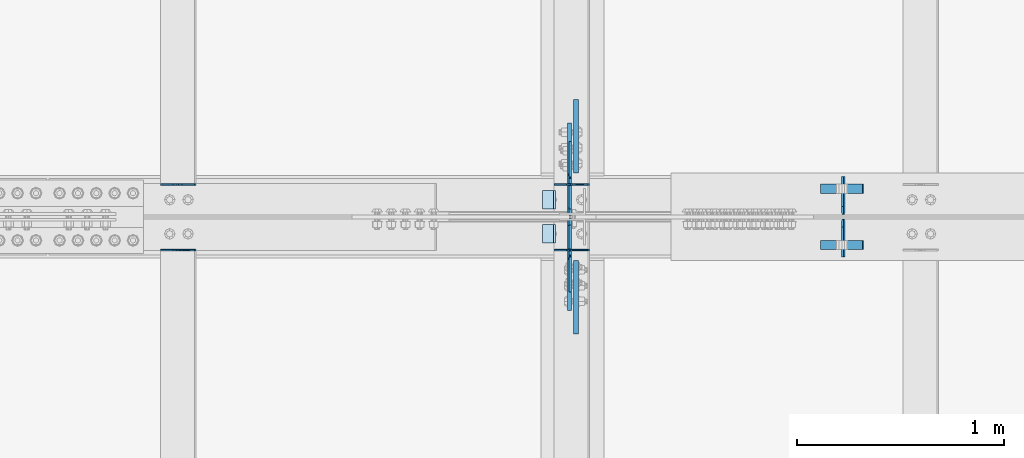
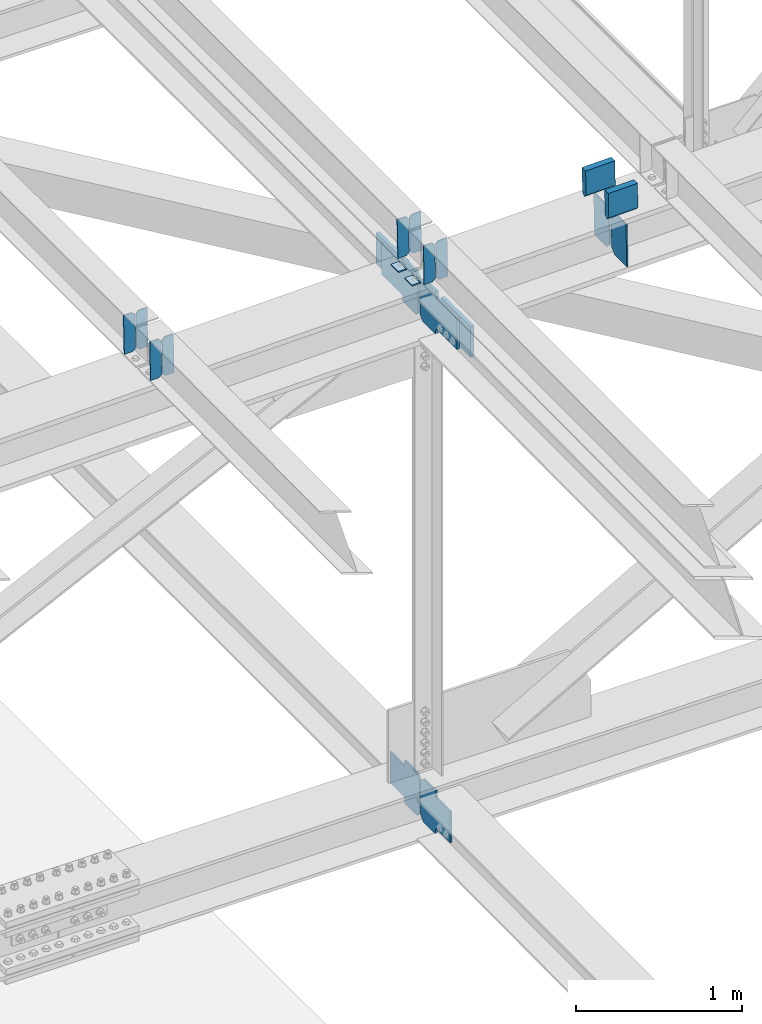
# One storey, part 3301 of 3843: 20 plates, 8 elements without a shape of their own.
"""IFC2X3 building model written with IfcOpenShell, lengths in millimetres."""

from ifc_helpers import new_model, si_unit, frame, origin_with_axes, place, context, subcontext, project, spatial, faceted_brep, material, type_object, element, aggregate, save


model = new_model("IFC2X3")

# Units and contexts
model_context = context("Model", 3, precision=1e-05, world=origin_with_axes())
body_context = subcontext(model_context, "Body", "Model", "MODEL_VIEW")
ifc_project = project(units=[si_unit("LENGTHUNIT", "METRE", prefix="MILLI"), si_unit("AREAUNIT", "SQUARE_METRE"), si_unit("VOLUMEUNIT", "CUBIC_METRE"), si_unit("MASSUNIT", "GRAM", prefix="KILO"), si_unit("TIMEUNIT", "SECOND"), si_unit("PLANEANGLEUNIT", "RADIAN"), si_unit("SOLIDANGLEUNIT", "STERADIAN"), si_unit("THERMODYNAMICTEMPERATUREUNIT", "DEGREE_CELSIUS"), si_unit("LUMINOUSINTENSITYUNIT", "LUMEN")], contexts=[model_context])

# Site, building, storey
site_placement = place(None, origin_with_axes())
site = spatial("IfcSite", under=ifc_project, at=site_placement, CompositionType="ELEMENT")
building_placement = place(site_placement, origin_with_axes())
building = spatial("IfcBuilding", under=site, at=building_placement, Name="Undefined", CompositionType="ELEMENT")
storey_placement = place(building_placement, origin_with_axes())
storey = spatial("IfcBuildingStorey", under=building, at=storey_placement, Name="Undefined", CompositionType="ELEMENT", Elevation=0.0)

# Assembly, plates
assembly_1_placement = place(storey_placement, origin_with_axes())
assembly_1 = element("IfcElementAssembly", 1, at=assembly_1_placement, inside=storey, Name="BEAM", AssemblyPlace="NOTDEFINED", PredefinedType="RIGID_FRAME")
ifc_material = material(Name="STEEL/A572-50")
plate_type_1 = type_object("IfcPlateType", PredefinedType="NOTDEFINED")
plate_1_placement = place(assembly_1_placement, frame((70338.6964783417, 42358.2999050559, 46224.2171587909), z_axis=(-0.0211520975484892, -0.00209727199913323, 0.999774069587455), x_axis=(-0.999776269356949, 4.43720000274898e-05, -0.0211520510075548)))
plate_1 = element("IfcPlate", 2, at=plate_1_placement, type_object=plate_type_1, material=ifc_material, Name="PLATE", context=body_context, shape_type="Brep", body=[
    faceted_brep([(0.0, -3.17499999999927, 0.0), (6.83940015733242e-10, -3.17499999996653, 288.924999998613), (6.54836185276508e-10, 3.17500000001746, 288.924999998591), (0.0, 3.17499999999927, 0.0), (60.3250007643655, -3.17500000017753, 288.924999998606), (60.3250007643219, 3.17499999979918, 288.924999998584), (79.3750000013097, -3.17500000025029, 269.875000761494), (79.375000001266, 3.17499999972642, 269.875000761487), (79.375000000713, -3.17500000026484, 19.0499992370605), (79.3750000006985, 3.17499999971187, 19.0499992370533), (60.325000763667, -3.17500000020664, -1.45519152283669e-11), (60.3250007636234, 3.17499999977736, -3.63797880709171e-11)], [[[0, 1, 2, 3]], [[1, 4, 5, 2]], [[4, 6, 7, 5]], [[6, 8, 9, 7]], [[8, 10, 11, 9]], [[10, 0, 3, 11]], [[5, 7, 9, 11, 3, 2]], [[10, 8, 6, 4, 1, 0]]]),
])
plate_2_placement = place(assembly_1_placement, frame((70252.9906576514, 42358.3037088136, 46222.4038991801), z_axis=(-0.0211520975484892, -0.00209727199913323, 0.999774069587455), x_axis=(-0.999776269356949, 4.43720000274898e-05, -0.0211520510075548)))
plate_2 = element("IfcPlate", 3, at=plate_2_placement, type_object=plate_type_1, material=ifc_material, Name="PLATE", context=body_context, shape_type="Brep", body=[
    faceted_brep([(4.36557456851006e-11, -3.17499999998836, 19.0499992370969), (6.11180439591408e-10, -3.17499999996653, 269.875000761516), (5.96628524363041e-10, 3.17500000001746, 269.875000761502), (1.45519152283669e-11, 3.17499999998836, 19.0499992370824), (19.0499992376572, -3.17500000003201, 288.924999998606), (19.0499992376281, 3.1749999999447, 288.924999998584), (79.3750000013242, -3.17500000025029, 288.924999998591), (79.3750000013097, 3.1749999997337, 288.92499999857), (79.3750000006548, -3.17500000026484, -2.18278728425503e-11), (79.3750000006403, 3.17499999969732, -2.91038304567337e-11), (19.0499992370023, -3.17500000005384, 0.0), (19.0499992369587, 3.17499999992287, -1.45519152283669e-11)], [[[0, 1, 2, 3]], [[1, 4, 5, 2]], [[4, 6, 7, 5]], [[6, 8, 9, 7]], [[8, 10, 11, 9]], [[10, 0, 3, 11]], [[5, 7, 9, 11, 3, 2]], [[10, 8, 6, 4, 1, 0]]]),
])

assembly_2_placement = place(storey_placement, origin_with_axes())
assembly_2 = element("IfcElementAssembly", 4, at=assembly_2_placement, inside=storey, Name="BEAM", AssemblyPlace="NOTDEFINED", PredefinedType="RIGID_FRAME")
plate_3_placement = place(assembly_2_placement, frame((70338.696478342, 42042.4624119039, 46222.6703412042), z_axis=(-0.021152098167775, -0.00763724799704507, 0.999747098613511), x_axis=(-0.999776269343847, 0.000161580000015114, -0.0211514810073172)))
plate_3 = element("IfcPlate", 5, at=plate_3_placement, type_object=plate_type_1, material=ifc_material, Name="PLATE", context=body_context, shape_type="Brep", body=[
    faceted_brep([(0.0, -3.17499999999927, 0.0), (6.83940015733242e-10, -3.17499999996653, 288.924999998613), (6.54836185276508e-10, 3.17500000001746, 288.924999998591), (0.0, 3.17499999999927, 0.0), (60.3250007643655, -3.17500000017753, 288.924999998606), (60.3250007643219, 3.17499999979918, 288.924999998584), (79.3750000013097, -3.17500000025029, 269.875000761494), (79.375000001266, 3.17499999972642, 269.875000761487), (79.375000000713, -3.17500000026484, 19.0499992370605), (79.3750000006985, 3.17499999971187, 19.0499992370533), (60.325000763667, -3.17500000020664, -1.45519152283669e-11), (60.3250007636234, 3.17499999977736, -3.63797880709171e-11)], [[[0, 1, 2, 3]], [[1, 4, 5, 2]], [[4, 6, 7, 5]], [[6, 8, 9, 7]], [[8, 10, 11, 9]], [[10, 0, 3, 11]], [[5, 7, 9, 11, 3, 2]], [[10, 8, 6, 4, 1, 0]]]),
])
plate_4_placement = place(assembly_2_placement, frame((70252.9906576517, 42042.4762633481, 46220.85713051), z_axis=(-0.021152098167775, -0.00763724799704507, 0.999747098613511), x_axis=(-0.999776269343847, 0.000161580000015114, -0.0211514810073172)))
plate_4 = element("IfcPlate", 6, at=plate_4_placement, type_object=plate_type_1, material=ifc_material, Name="PLATE", context=body_context, shape_type="Brep", body=[
    faceted_brep([(4.36557456851006e-11, -3.17499999998836, 19.0499992370969), (6.11180439591408e-10, -3.17499999996653, 269.875000761516), (5.96628524363041e-10, 3.17500000001746, 269.875000761502), (1.45519152283669e-11, 3.17499999998836, 19.0499992370824), (19.0499992376572, -3.17500000003201, 288.924999998606), (19.0499992376281, 3.1749999999447, 288.924999998584), (79.3750000013242, -3.17500000025029, 288.924999998591), (79.3750000013097, 3.1749999997337, 288.92499999857), (79.3750000006548, -3.17500000026484, -2.18278728425503e-11), (79.3750000006403, 3.17499999969732, -2.91038304567337e-11), (19.0499992370023, -3.17500000005384, 0.0), (19.0499992369587, 3.17499999992287, -1.45519152283669e-11)], [[[0, 1, 2, 3]], [[1, 4, 5, 2]], [[4, 6, 7, 5]], [[6, 8, 9, 7]], [[8, 10, 11, 9]], [[10, 0, 3, 11]], [[5, 7, 9, 11, 3, 2]], [[10, 8, 6, 4, 1, 0]]]),
])

assembly_3_placement = place(storey_placement, origin_with_axes())
assembly_3 = element("IfcElementAssembly", 7, at=assembly_3_placement, inside=storey, Name="BEAM", AssemblyPlace="NOTDEFINED", PredefinedType="RIGID_FRAME")
plate_5_placement = place(assembly_3_placement, frame((68433.6964782794, 42358.2874346578, 46184.4953041422), z_axis=(-0.0211520977063192, -0.00205537399917375, 0.999774156597552), x_axis=(-0.999776269341419, 4.27870000128944e-05, -0.0211520550071887)))
plate_5 = element("IfcPlate", 8, at=plate_5_placement, type_object=plate_type_1, material=ifc_material, Name="PLATE", context=body_context, shape_type="Brep", body=[
    faceted_brep([(0.0, -3.17499999999927, 0.0), (6.83940015733242e-10, -3.17499999996653, 288.924999998613), (6.54836185276508e-10, 3.17500000001746, 288.924999998591), (0.0, 3.17499999999927, 0.0), (60.3250007643655, -3.17500000017753, 288.924999998606), (60.3250007643219, 3.17499999979918, 288.924999998584), (79.3750000013097, -3.17500000025029, 269.875000761494), (79.375000001266, 3.17499999972642, 269.875000761487), (79.375000000713, -3.17500000026484, 19.0499992370605), (79.3750000006985, 3.17499999971187, 19.0499992370533), (60.325000763667, -3.17500000020664, -1.45519152283669e-11), (60.3250007636234, 3.17499999977736, -3.63797880709171e-11)], [[[0, 1, 2, 3]], [[1, 4, 5, 2]], [[4, 6, 7, 5]], [[6, 8, 9, 7]], [[8, 10, 11, 9]], [[10, 0, 3, 11]], [[5, 7, 9, 11, 3, 2]], [[10, 8, 6, 4, 1, 0]]]),
])
plate_6_placement = place(assembly_3_placement, frame((68347.9906575891, 42358.291162427, 46182.6820443736), z_axis=(-0.0211520977063192, -0.00205537399917375, 0.999774156597552), x_axis=(-0.999776269341419, 4.27870000128944e-05, -0.0211520550071887)))
plate_6 = element("IfcPlate", 9, at=plate_6_placement, type_object=plate_type_1, material=ifc_material, Name="PLATE", context=body_context, shape_type="Brep", body=[
    faceted_brep([(4.36557456851006e-11, -3.17499999998836, 19.0499992370969), (6.11180439591408e-10, -3.17499999996653, 269.875000761516), (5.96628524363041e-10, 3.17500000001746, 269.875000761502), (1.45519152283669e-11, 3.17499999998836, 19.0499992370824), (19.0499992376572, -3.17500000003201, 288.924999998606), (19.0499992376281, 3.1749999999447, 288.924999998584), (79.3750000013242, -3.17500000025029, 288.924999998591), (79.3750000013097, 3.1749999997337, 288.92499999857), (79.3750000006548, -3.17500000026484, -2.18278728425503e-11), (79.3750000006403, 3.17499999969732, -2.91038304567337e-11), (19.0499992370023, -3.17500000005384, 0.0), (19.0499992369587, 3.17499999992287, -1.45519152283669e-11)], [[[0, 1, 2, 3]], [[1, 4, 5, 2]], [[4, 6, 7, 5]], [[6, 8, 9, 7]], [[8, 10, 11, 9]], [[10, 0, 3, 11]], [[5, 7, 9, 11, 3, 2]], [[10, 8, 6, 4, 1, 0]]]),
])
aggregate(assembly_3, [plate_5, plate_6])

assembly_4_placement = place(storey_placement, origin_with_axes())
assembly_4 = element("IfcElementAssembly", 10, at=assembly_4_placement, inside=storey, Name="BEAM", AssemblyPlace="NOTDEFINED", PredefinedType="RIGID_FRAME")
plate_7_placement = place(assembly_4_placement, frame((68433.6964782755, 42042.5166516229, 46182.926700833), z_axis=(-0.0211520976633037, -0.00781760099692474, 0.999745704606474), x_axis=(-0.99977626935452, 0.000165396000026019, -0.0211514510074668)))
plate_7 = element("IfcPlate", 11, at=plate_7_placement, type_object=plate_type_1, material=ifc_material, Name="PLATE", context=body_context, shape_type="Brep", body=[
    faceted_brep([(0.0, -3.17499999999927, 0.0), (6.83940015733242e-10, -3.17499999996653, 288.924999998613), (6.54836185276508e-10, 3.17500000001746, 288.924999998591), (0.0, 3.17499999999927, 0.0), (60.3250007643655, -3.17500000017753, 288.924999998606), (60.3250007643219, 3.17499999979918, 288.924999998584), (79.3750000013097, -3.17500000025029, 269.875000761494), (79.375000001266, 3.17499999972642, 269.875000761487), (79.375000000713, -3.17500000026484, 19.0499992370605), (79.3750000006985, 3.17499999971187, 19.0499992370533), (60.325000763667, -3.17500000020664, -1.45519152283669e-11), (60.3250007636234, 3.17499999977736, -3.63797880709171e-11)], [[[0, 1, 2, 3]], [[1, 4, 5, 2]], [[4, 6, 7, 5]], [[6, 8, 9, 7]], [[8, 10, 11, 9]], [[10, 0, 3, 11]], [[5, 7, 9, 11, 3, 2]], [[10, 8, 6, 4, 1, 0]]]),
])
plate_8_placement = place(assembly_4_placement, frame((68347.9906575843, 42042.5308301672, 46181.1134926668), z_axis=(-0.0211520976633037, -0.00781760099692474, 0.999745704606474), x_axis=(-0.99977626935452, 0.000165396000026019, -0.0211514510074668)))
plate_8 = element("IfcPlate", 12, at=plate_8_placement, type_object=plate_type_1, material=ifc_material, Name="PLATE", context=body_context, shape_type="Brep", body=[
    faceted_brep([(4.36557456851006e-11, -3.17499999998836, 19.0499992370969), (6.11180439591408e-10, -3.17499999996653, 269.875000761516), (5.96628524363041e-10, 3.17500000001746, 269.875000761502), (1.45519152283669e-11, 3.17499999998836, 19.0499992370824), (19.0499992376572, -3.17500000003201, 288.924999998606), (19.0499992376281, 3.1749999999447, 288.924999998584), (79.3750000013242, -3.17500000025029, 288.924999998591), (79.3750000013097, 3.1749999997337, 288.92499999857), (79.3750000006548, -3.17500000026484, -2.18278728425503e-11), (79.3750000006403, 3.17499999969732, -2.91038304567337e-11), (19.0499992370023, -3.17500000005384, 0.0), (19.0499992369587, 3.17499999992287, -1.45519152283669e-11)], [[[0, 1, 2, 3]], [[1, 4, 5, 2]], [[4, 6, 7, 5]], [[6, 8, 9, 7]], [[8, 10, 11, 9]], [[10, 0, 3, 11]], [[5, 7, 9, 11, 3, 2]], [[10, 8, 6, 4, 1, 0]]]),
])
aggregate(assembly_4, [plate_7, plate_8])

assembly_5_placement = place(storey_placement, origin_with_axes())
assembly_5 = element("IfcElementAssembly", 13, at=assembly_5_placement, inside=storey, Name="BEAM", AssemblyPlace="NOTDEFINED", PredefinedType="RIGID_FRAME")
plate_type_2 = type_object("IfcPlateType", PredefinedType="NOTDEFINED")
plate_9_placement = place(assembly_5_placement, frame((71570.2670568433, 42006.5375, 45882.7692935565), z_axis=(-0.0197786729982909, 0.0, 0.999804382914191), x_axis=(0.0, 1.0, 0.0)))
plate_9 = element("IfcPlate", 14, at=plate_9_placement, type_object=plate_type_2, material=ifc_material, Name="PL", context=body_context, shape_type="Brep", body=[
    faceted_brep([(0.0, -4.76249999999709, 0.0), (0.0, -4.76249999986612, 316.893560966142), (0.0, 4.7625000000844, 316.893560966142), (0.0, 4.76249999999709, 0.0), (145.746763610834, -4.76249999986612, 316.893560966142), (145.746763610834, 4.7625000000844, 316.893560966142), (184.149999999994, -4.76249999989523, 278.490324577106), (184.149999999994, 4.76250000006985, 278.490324577098), (184.149999999994, -4.76249999999709, 38.4032363890365), (184.149999999994, 4.76249999998254, 38.4032363890365), (145.746763610834, -4.76250000001164, 7.27595761418343e-12), (145.746763610834, 4.76249999995343, 0.0)], [[[0, 1, 2, 3]], [[1, 4, 5, 2]], [[4, 6, 7, 5]], [[6, 8, 9, 7]], [[8, 10, 11, 9]], [[10, 0, 3, 11]], [[5, 7, 9, 11, 3, 2]], [[10, 8, 6, 4, 1, 0]]]),
])
plate_10_placement = place(assembly_5_placement, frame((71570.2670568433, 42213.5125, 45882.7692935565), z_axis=(-0.0197786729982909, 0.0, 0.999804382914191), x_axis=(0.0, 1.0, 0.0)))
plate_10 = element("IfcPlate", 15, at=plate_10_placement, type_object=plate_type_2, material=ifc_material, Name="PL", context=body_context, shape_type="Brep", body=[
    faceted_brep([(0.0, -4.76249999999709, 38.4032363890365), (0.0, -4.76249999989523, 278.490324577106), (0.0, 4.76250000006985, 278.490324577098), (0.0, 4.76249999998254, 38.4032363890365), (38.4032363891602, -4.76249999986612, 316.893560966142), (38.4032363891602, 4.7625000000844, 316.893560966142), (184.149999999994, -4.76249999986612, 316.893560966142), (184.149999999994, 4.7625000000844, 316.893560966142), (184.150000000009, -4.76249999999709, 0.0), (184.150000000009, 4.76249999999709, 0.0), (38.4032363891602, -4.76250000001164, 7.27595761418343e-12), (38.4032363891602, 4.76249999995343, 0.0)], [[[0, 1, 2, 3]], [[1, 4, 5, 2]], [[4, 6, 7, 5]], [[6, 8, 9, 7]], [[8, 10, 11, 9]], [[10, 0, 3, 11]], [[5, 7, 9, 11, 3, 2]], [[10, 8, 6, 4, 1, 0]]]),
])
plate_type_3 = type_object("IfcPlateType", PredefinedType="NOTDEFINED")
plate_11_placement = place(assembly_5_placement, frame((71457.1973583089, 42338.228125, 46438.8455084211), z_axis=(0.0217666070074993, 0.0, -0.999763079343992), x_axis=(0.999763079343992, 0.0, 0.0217666070075027)))
plate_11 = element("IfcPlate", 16, at=plate_11_placement, type_object=plate_type_3, material=ifc_material, Name="PLATE", context=body_context, shape_type="Brep", body=[
    faceted_brep([(203.200005058941, -22.2250000000058, -1.16415321826935e-10), (7.27595761418343e-12, -22.2250000000058, -7.27595761418343e-12), (7.27595761418343e-12, 22.2250000000058, -7.27595761418343e-12), (203.200005058941, 22.2250000000058, -1.16415321826935e-10), (203.838531807472, -22.2250000000058, 0.00187068080413155), (203.838531807472, 22.2250000000058, 0.00187068080413155), (203.310341304641, -22.2250000000058, 180.861817383484), (0.04046799018397, -22.2250000000058, 180.907287948779), (203.245434494536, 0.0133131837355904, 203.086833080139), (0.0454396034692763, 0.0133129994646879, 203.132287829787), (0.0404679902494536, 22.2250000000058, 180.907288225317), (203.310341303353, 22.2250000000058, 180.861817822159)], [[[0, 1, 2, 3]], [[4, 0, 3, 5]], [[1, 0, 4, 6, 7]], [[7, 6, 8, 9]], [[2, 1, 7, 9, 10]], [[5, 3, 2, 10, 11]], [[6, 4, 5, 11, 8]], [[10, 9, 8, 11]]]),
])
plate_12_placement = place(assembly_5_placement, frame((71457.1973583089, 42065.178125, 46438.8455084211), z_axis=(0.0217666070074993, 0.0, -0.999763079343992), x_axis=(0.999763079343992, 0.0, 0.0217666070075027)))
plate_12 = element("IfcPlate", 17, at=plate_12_placement, type_object=plate_type_3, material=ifc_material, Name="PLATE", context=body_context, shape_type="Brep", body=[
    faceted_brep([(203.200005058941, -22.2250000000058, -1.16415321826935e-10), (7.27595761418343e-12, -22.2250000000058, -7.27595761418343e-12), (7.27595761418343e-12, 22.2250000000058, -7.27595761418343e-12), (203.200005058941, 22.2250000000058, -1.16415321826935e-10), (203.838531807472, -22.2250000000058, 0.00187068080413155), (203.838531807472, 22.2250000000058, 0.00187068080413155), (203.310341304641, -22.2250000000058, 180.861817383484), (0.04046799018397, -22.2250000000058, 180.907287948779), (203.245434494536, 0.0133131837355904, 203.086833080139), (0.0454396034692763, 0.0133129994646879, 203.132287829787), (0.0404679902494536, 22.2250000000058, 180.907288225317), (203.310341303353, 22.2250000000058, 180.861817822159)], [[[0, 1, 2, 3]], [[4, 0, 3, 5]], [[1, 0, 4, 6, 7]], [[7, 6, 8, 9]], [[2, 1, 7, 9, 10]], [[5, 3, 2, 10, 11]], [[6, 4, 5, 11, 8]], [[10, 9, 8, 11]]]),
])

# Plate
plate_type_4 = type_object("IfcPlateType", PredefinedType="NOTDEFINED")
plate_13_placement = place(assembly_1_placement, frame((70173.7677249184, 42329.1, 46214.0490181074), z_axis=(0.0, -1.0, 0.0), x_axis=(-0.999776270257024, 0.0, -0.0211520550054595)))
plate_13 = element("IfcPlate", 18, at=plate_13_placement, type_object=plate_type_4, material=ifc_material, Name="PLATE", context=body_context, shape_type="Brep", body=[
    faceted_brep([(9.52499999982683, -4.7625000001135, 88.8999999999942), (0.0, 4.76249999999709, 88.9000015258789), (0.0, 4.76249999999709, 0.0), (9.52499999981956, -4.76249999999709, 0.0), (63.4999984608512, -4.76249999988795, 88.8999999999796), (63.4999984608367, -4.76249999988795, -1.45519152283669e-11), (63.4999984608221, 4.76250000013533, -1.45519152283669e-11), (63.4999984608367, 4.76250000013533, 88.8999999999796)], [[[0, 1, 2, 3]], [[4, 5, 6, 7]], [[5, 4, 0, 3]], [[6, 5, 3, 2]], [[7, 6, 2, 1]], [[4, 7, 1, 0]]]),
])

aggregate(assembly_1, [plate_1, plate_2, plate_13])

plate_14_placement = place(assembly_2_placement, frame((70173.7677249184, 42164.0000015258, 46214.0490181074), z_axis=(0.0, -1.0, 0.0), x_axis=(-0.999776270257024, 0.0, -0.0211520550054595)))
plate_14 = element("IfcPlate", 19, at=plate_14_placement, type_object=plate_type_4, material=ifc_material, Name="PLATE", context=body_context, shape_type="Brep", body=[
    faceted_brep([(9.52499999982683, -4.7625000001135, 88.8999999999942), (0.0, 4.76249999999709, 88.9000015258789), (0.0, 4.76249999999709, 0.0), (9.52499999981956, -4.76249999999709, 0.0), (63.4999984608512, -4.76249999988795, 88.8999999999796), (63.4999984608367, -4.76249999988795, -1.45519152283669e-11), (63.4999984608221, 4.76250000013533, -1.45519152283669e-11), (63.4999984608367, 4.76250000013533, 88.8999999999796)], [[[0, 1, 2, 3]], [[4, 5, 6, 7]], [[5, 4, 0, 3]], [[6, 5, 3, 2]], [[7, 6, 2, 1]], [[4, 7, 1, 0]]]),
])

aggregate(assembly_2, [plate_3, plate_4, plate_14])

# Assembly, plates
assembly_6_placement = place(storey_placement, origin_with_axes())
assembly_6 = element("IfcElementAssembly", 20, at=assembly_6_placement, inside=storey, Name="BEAM", AssemblyPlace="NOTDEFINED", PredefinedType="RIGID_FRAME")
plate_type_5 = type_object("IfcPlateType", PredefinedType="NOTDEFINED")
plate_15_placement = place(assembly_6_placement, frame((70245.2875040623, 42209.2437499953, 42199.6849668428), z_axis=(0.0, 0.707106781186548, 0.707106781186548), x_axis=(5.70000238222118e-08, 0.707106781186546, -0.707106781186546)))
plate_15 = element("IfcPlate", 21, at=plate_15_placement, type_object=plate_type_5, material=ifc_material, Name="PLATE", context=body_context, shape_type="Brep", body=[
    faceted_brep([(0.0, -6.3499999046162, 0.0), (-179.600911024743, -6.35000000000582, 179.600911024711), (-179.600911024743, 6.35000000000582, 179.600911024711), (7.27595761418343e-12, 6.3499999046162, 0.0), (-179.600911024292, -6.35000000000582, 224.502191630294), (-179.600911024292, 6.35000000000582, 224.502191630294), (-75.7666996228036, -6.35000000000582, 328.336403031819), (-75.7666996228036, 6.35000000000582, 328.336403031819), (-53.6739968439215, -6.35000000000582, 306.243700567276), (-53.6739968439215, 6.35000000000582, 306.243700567276), (-49.5538203757787, -6.35000000000582, 303.49068666681), (-49.5538203757787, 6.35000000000582, 303.49068666681), (-44.6937408577505, -6.35000000000582, 302.523956744226), (-44.6937408577505, 6.35000000000582, 302.523956744226), (-39.8336613397114, -6.35000000000582, 303.49068666681), (-39.8336613397114, 6.35000000000582, 303.49068666681), (-35.7134848715723, -6.35000000000582, 306.243700567291), (-35.7134848715723, 6.35000000000582, 306.243700567291), (81.0298446768647, -6.35000000000582, 422.987030115728), (81.0298446768647, 6.35000000000582, 422.987030115728), (242.674454855336, -6.35000000000582, 261.342419937246), (242.674454855336, 6.35000000000582, 261.342419937246), (125.931125306903, -6.35000000000582, 144.599090388809), (125.931125306903, 6.35000000000582, 144.599090388809), (123.178111406425, -6.35000000000582, 140.47891392067), (123.178111406425, 6.35000000000582, 140.47891392067), (122.211381483845, -6.35000000000582, 135.618834402638), (122.211381483845, 6.35000000000582, 135.618834402638), (123.178111406425, -6.35000000000582, 130.758754884606), (123.178111406425, 6.35000000000582, 130.758754884606), (125.931125306903, -6.35000000000582, 126.638578416452), (125.931125306903, 6.35000000000582, 126.638578416452), (148.735492004496, -6.35000000000582, 103.834211399357), (148.735492004496, 6.35000000000582, 103.834211399357), (44.9012806051323, -6.35000000000582, -1.45519152283669e-11), (44.9012806051323, 6.35000000000582, -1.45519152283669e-11)], [[[0, 1, 2, 3]], [[1, 4, 5, 2]], [[4, 6, 7, 5]], [[6, 8, 9, 7]], [[8, 10, 11, 9]], [[10, 12, 13, 11]], [[12, 14, 15, 13]], [[14, 16, 17, 15]], [[16, 18, 19, 17]], [[18, 20, 21, 19]], [[20, 22, 23, 21]], [[22, 24, 25, 23]], [[24, 26, 27, 25]], [[26, 28, 29, 27]], [[28, 30, 31, 29]], [[30, 32, 33, 31]], [[32, 34, 35, 33]], [[34, 0, 3, 35]], [[5, 7, 9, 11, 13, 15, 17, 19, 21, 23, 25, 27, 29, 31, 33, 35, 3, 2]], [[34, 32, 30, 28, 26, 24, 22, 20, 18, 16, 14, 12, 10, 8, 6, 4, 1, 0]]]),
])
plate_16_placement = place(assembly_6_placement, frame((70245.2875706603, 42194.9562499931, 42199.6849667738), z_axis=(0.0, -0.707106781186682, 0.707106781186413), x_axis=(0.0, -0.707106781186548, -0.707106781186548)))
plate_16 = element("IfcPlate", 22, at=plate_16_placement, type_object=plate_type_5, material=ifc_material, Name="PLATE", context=body_context, shape_type="Brep", body=[
    faceted_brep([(0.0, -6.3499999046162, 0.0), (-179.600911024743, -6.35000000000582, 179.600911024711), (-179.600911024743, 6.35000000000582, 179.600911024711), (7.27595761418343e-12, 6.3499999046162, 0.0), (-179.600911024292, -6.35000000000582, 224.502191630294), (-179.600911024292, 6.35000000000582, 224.502191630294), (-75.7666996228036, -6.35000000000582, 328.336403031819), (-75.7666996228036, 6.35000000000582, 328.336403031819), (-52.0017830885554, -6.35000000000582, 304.571486497589), (-52.0017830885554, 6.35000000000582, 304.571486497589), (-47.881606620409, -6.35000000000582, 301.818472597122), (-47.881606620409, 6.35000000000582, 301.818472597122), (-43.021527102348, -6.35000000000582, 300.851742674553), (-43.021527102348, 6.35000000000582, 300.851742674553), (-38.1614475842907, -6.35000000000582, 301.818472597166), (-38.1614475842907, 6.35000000000582, 301.818472597166), (-34.0412711161152, -6.35000000000582, 304.571486497676), (-34.0412711161152, 6.35000000000582, 304.571486497676), (82.7020585945538, -6.35000000000582, 421.314816208367), (82.7020585945538, 6.35000000000582, 421.314816208367), (244.346668773043, -6.35000000000582, 259.670206029914), (244.346668773043, 6.35000000000582, 259.670206029914), (127.603339062382, -6.35000000000582, 142.926876319238), (127.603339062382, 6.35000000000582, 142.926876319238), (124.850325161875, -6.35000000000582, 138.806699851033), (124.850325161875, 6.35000000000582, 138.806699851033), (123.883595239262, -6.35000000000582, 133.946620332979), (123.883595239262, 6.35000000000582, 133.946620332979), (124.850325161824, -6.35000000000582, 129.086540814926), (124.850325161824, 6.35000000000582, 129.086540814926), (127.603339062291, -6.35000000000582, 124.966364346779), (127.603339062291, 6.35000000000582, 124.966364346779), (148.735492004496, -6.35000000000582, 103.834211399357), (148.735492004496, 6.35000000000582, 103.834211399357), (44.9012806051323, -6.35000000000582, -1.45519152283669e-11), (44.9012806051323, 6.35000000000582, -1.45519152283669e-11)], [[[0, 1, 2, 3]], [[1, 4, 5, 2]], [[4, 6, 7, 5]], [[6, 8, 9, 7]], [[8, 10, 11, 9]], [[10, 12, 13, 11]], [[12, 14, 15, 13]], [[14, 16, 17, 15]], [[16, 18, 19, 17]], [[18, 20, 21, 19]], [[20, 22, 23, 21]], [[22, 24, 25, 23]], [[24, 26, 27, 25]], [[26, 28, 29, 27]], [[28, 30, 31, 29]], [[30, 32, 33, 31]], [[32, 34, 35, 33]], [[34, 0, 3, 35]], [[5, 7, 9, 11, 13, 15, 17, 19, 21, 23, 25, 27, 29, 31, 33, 35, 3, 2]], [[34, 32, 30, 28, 26, 24, 22, 20, 18, 16, 14, 12, 10, 8, 6, 4, 1, 0]]]),
])
aggregate(assembly_6, [plate_15, plate_16])

# Plate
plate_type_6 = type_object("IfcPlateType", PredefinedType="NOTDEFINED")
plate_17_placement = place(assembly_5_placement, frame((70242.1124996608, 42213.2125, 45887.0097799256), z_axis=(0.0, 0.707106781186548, 0.707106781186548), x_axis=(5.70000238222118e-08, 0.707106781186546, -0.707106781186546)))
plate_17 = element("IfcPlate", 23, at=plate_17_placement, type_object=plate_type_6, material=ifc_material, Name="PLATE", context=body_context, shape_type="Brep", body=[
    faceted_brep([(0.0, -9.52500000000146, 0.0), (-179.374759414153, -9.52499999999418, 179.374759414153), (-179.374759414153, 9.52499999999418, 179.374759414153), (0.0, 9.52500000000146, 0.0), (-179.374759414153, -9.52499999999418, 224.276040019286), (-179.374759414153, 9.52499999999418, 224.276040019286), (-68.2440899164244, -9.52499999999418, 335.40670951701), (-68.2440899164244, 9.52499999999418, 335.40670951701), (-46.4985863436045, -9.52499999999418, 313.66120594419), (-46.4985863436045, 9.52499999999418, 313.66120594419), (-42.3784098754618, -9.52499999999418, 310.908192043709), (-42.3784098754618, 9.52499999999418, 310.908192043709), (-37.5183303574263, -9.52499999999418, 309.941462121133), (-37.5183303574263, 9.52499999999418, 309.941462121133), (-32.6582508393944, -9.52499999999418, 310.908192043709), (-32.6582508393944, 9.52499999999418, 310.908192043709), (-28.5380743712553, -9.52499999999418, 313.661205944183), (-28.5380743712553, 9.52499999999418, 313.661205944183), (142.086792063067, -9.52499999999418, 484.286072378491), (142.086792063067, 9.52499999999418, 484.286072378491), (303.731402241534, -9.52499999999418, 322.641462200037), (303.731402241534, 9.52499999999418, 322.641462200037), (133.106535807216, -9.52499999999418, 152.016595765708), (133.106535807216, 9.52499999999418, 152.016595765708), (130.353521906746, -9.52499999999418, 147.896419297569), (130.353521906746, 9.52499999999418, 147.896419297569), (129.386791984162, -9.52499999999418, 143.03633977953), (129.386791984162, 9.52499999999418, 143.03633977953), (130.353521906742, -9.52499999999418, 138.176260261498), (130.353521906742, 9.52499999999418, 138.176260261498), (133.10653580722, -9.52499999999418, 134.056083793352), (133.10653580722, 9.52499999999418, 134.056083793352), (156.031950102854, -9.52499999999418, 111.130669497732), (156.031950102854, 9.52499999999418, 111.130669497732), (44.9012806055835, -9.52499999999418, 4.65661287307739e-10), (44.9012806055835, 9.52499999999418, 4.65661287307739e-10)], [[[0, 1, 2, 3]], [[1, 4, 5, 2]], [[4, 6, 7, 5]], [[6, 8, 9, 7]], [[8, 10, 11, 9]], [[10, 12, 13, 11]], [[12, 14, 15, 13]], [[14, 16, 17, 15]], [[16, 18, 19, 17]], [[18, 20, 21, 19]], [[20, 22, 23, 21]], [[22, 24, 25, 23]], [[24, 26, 27, 25]], [[26, 28, 29, 27]], [[28, 30, 31, 29]], [[30, 32, 33, 31]], [[32, 34, 35, 33]], [[34, 0, 3, 35]], [[5, 7, 9, 11, 13, 15, 17, 19, 21, 23, 25, 27, 29, 31, 33, 35, 3, 2]], [[34, 32, 30, 28, 26, 24, 22, 20, 18, 16, 14, 12, 10, 8, 6, 4, 1, 0]]]),
])

plate_18_placement = place(assembly_5_placement, frame((70242.1125703546, 42190.9874999674, 45887.0097800602), z_axis=(0.0, -0.707106781186682, 0.707106781186413), x_axis=(0.0, -0.707106781186548, -0.707106781186548)))
plate_18 = element("IfcPlate", 24, at=plate_18_placement, type_object=plate_type_6, material=ifc_material, Name="PLATE", context=body_context, shape_type="Brep", body=[
    faceted_brep([(0.0, -9.52500000000146, 0.0), (-179.374759414153, -9.52499999999418, 179.374759414153), (-179.374759414153, 9.52499999999418, 179.374759414153), (0.0, 9.52500000000146, 0.0), (-179.374759414153, -9.52499999999418, 224.276040019286), (-179.374759414153, 9.52499999999418, 224.276040019286), (-68.2440899164244, -9.52499999999418, 335.40670951701), (-68.2440899164244, 9.52499999999418, 335.40670951701), (-44.7277937285035, -9.52499999999418, 311.890413331789), (-44.7277937285035, 9.52499999999418, 311.890413331789), (-40.6076172603571, -9.52499999999418, 309.137399431323), (-40.6076172603571, 9.52499999999418, 309.137399431323), (-35.7475377423252, -9.52499999999418, 308.170669508731), (-35.7475377423252, 9.52499999999418, 308.170669508731), (-30.8874582242934, -9.52499999999418, 309.137399431323), (-30.8874582242934, 9.52499999999418, 309.137399431323), (-26.767281756147, -9.52499999999418, 311.890413331793), (-26.767281756147, 9.52499999999418, 311.890413331793), (143.85758468003, -9.52499999999418, 482.51527976797), (143.85758468003, 9.52499999999418, 482.51527976797), (305.502194858491, -9.52499999999418, 320.870669589513), (305.502194858491, 9.52499999999418, 320.870669589513), (134.877328422313, -9.52499999999418, 150.245803153336), (134.877328422313, 9.52499999999418, 150.245803153336), (132.124314521847, -9.52499999999418, 146.125626685182), (132.124314521847, 9.52499999999418, 146.125626685182), (131.157584599256, -9.52499999999418, 141.265547167154), (131.157584599256, 9.52499999999418, 141.265547167154), (132.124314521847, -9.52499999999418, 136.405467649119), (132.124314521847, 9.52499999999418, 136.405467649119), (134.877328422321, -9.52499999999418, 132.285291180976), (134.877328422321, 9.52499999999418, 132.285291180976), (156.031950102854, -9.52499999999418, 111.130669497732), (156.031950102854, 9.52499999999418, 111.130669497732), (44.9012806055835, -9.52499999999418, 4.65661287307739e-10), (44.9012806055835, 9.52499999999418, 4.65661287307739e-10)], [[[0, 1, 2, 3]], [[1, 4, 5, 2]], [[4, 6, 7, 5]], [[6, 8, 9, 7]], [[8, 10, 11, 9]], [[10, 12, 13, 11]], [[12, 14, 15, 13]], [[14, 16, 17, 15]], [[16, 18, 19, 17]], [[18, 20, 21, 19]], [[20, 22, 23, 21]], [[22, 24, 25, 23]], [[24, 26, 27, 25]], [[26, 28, 29, 27]], [[28, 30, 31, 29]], [[30, 32, 33, 31]], [[32, 34, 35, 33]], [[34, 0, 3, 35]], [[5, 7, 9, 11, 13, 15, 17, 19, 21, 23, 25, 27, 29, 31, 33, 35, 3, 2]], [[34, 32, 30, 28, 26, 24, 22, 20, 18, 16, 14, 12, 10, 8, 6, 4, 1, 0]]]),
])

aggregate(assembly_5, [plate_9, plate_10, plate_11, plate_12, plate_17, plate_18])

# Assembly, plate
assembly_7_placement = place(storey_placement, origin_with_axes())
assembly_7 = element("IfcElementAssembly", 25, at=assembly_7_placement, inside=storey, Name="BEAM", AssemblyPlace="NOTDEFINED", PredefinedType="RIGID_FRAME")
plate_type_7 = type_object("IfcPlateType", PredefinedType="NOTDEFINED")
plate_19_placement = place(assembly_7_placement, frame((70273.8624914684, 42414.8247671455, 45900.3664974151), z_axis=(0.0, 1.0, 0.0), x_axis=(0.0, 0.0, 1.0)))
plate_19 = element("IfcPlate", 26, at=plate_19_placement, type_object=plate_type_7, material=ifc_material, Name="PLATE", context=body_context, shape_type="Brep", body=[
    faceted_brep([(0.0, -12.6999999999971, 0.0), (0.0147141397246742, -12.7000000013795, 355.599999695551), (0.0147141397246742, 12.6999999986292, 355.599999695653), (0.0, 12.6999999999971, 0.0), (228.629514935208, -12.7000000013795, 355.599999692029), (228.629514935208, 12.6999999986292, 355.599999692131), (228.614714160503, -12.6999999999971, 4.36557456851006e-11), (228.614714160503, 12.6999999999971, 1.45519152283669e-10)], [[[0, 1, 2, 3]], [[1, 4, 5, 2]], [[4, 6, 7, 5]], [[6, 0, 3, 7]], [[5, 7, 3, 2]], [[6, 4, 1, 0]]]),
])
aggregate(assembly_7, [plate_19])

assembly_8_placement = place(storey_placement, origin_with_axes())
assembly_8 = element("IfcElementAssembly", 27, at=assembly_8_placement, inside=storey, Name="BEAM", AssemblyPlace="NOTDEFINED", PredefinedType="RIGID_FRAME")
plate_20_placement = place(assembly_8_placement, frame((70273.8624914684, 41633.7750001386, 45897.8769831604), z_axis=(0.0, 1.0, 0.0), x_axis=(0.0, 0.0, 1.0)))
plate_20 = element("IfcPlate", 28, at=plate_20_placement, type_object=plate_type_7, material=ifc_material, Name="PLATE", context=body_context, shape_type="Brep", body=[
    faceted_brep([(0.0, -12.6999999999971, 0.0), (0.0147141397246742, -12.7000000013795, 355.599999695551), (0.0147141397246742, 12.6999999986292, 355.599999695653), (0.0, 12.6999999999971, 0.0), (228.599998464349, -12.7000000013795, 355.599999691767), (228.599998464349, 12.6999999986292, 355.599999691869), (228.585197689645, -12.6999999999825, -2.18278728425503e-10), (228.585197689645, 12.7000000000116, -1.16415321826935e-10)], [[[0, 1, 2, 3]], [[1, 4, 5, 2]], [[4, 6, 7, 5]], [[6, 0, 3, 7]], [[5, 7, 3, 2]], [[6, 4, 1, 0]]]),
])
aggregate(assembly_8, [plate_20])

save(model, "model.ifc")
